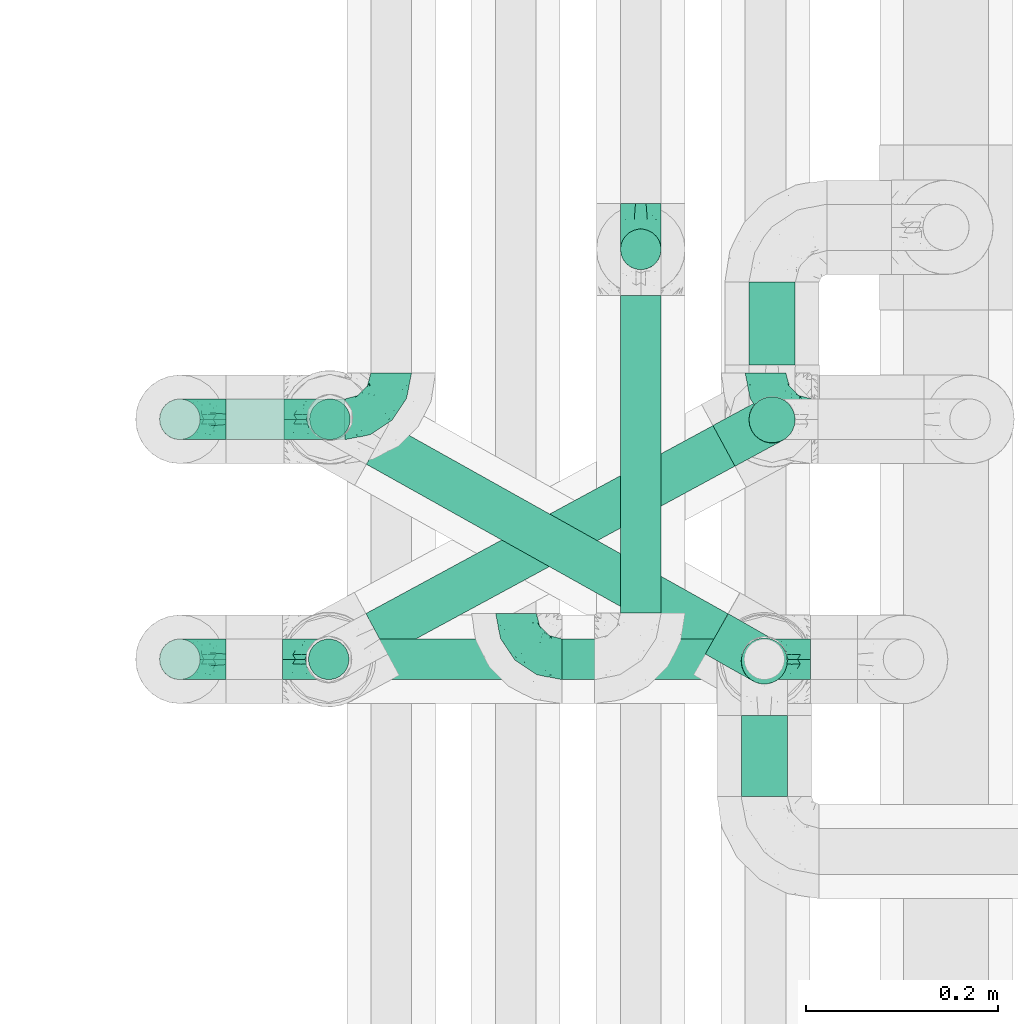
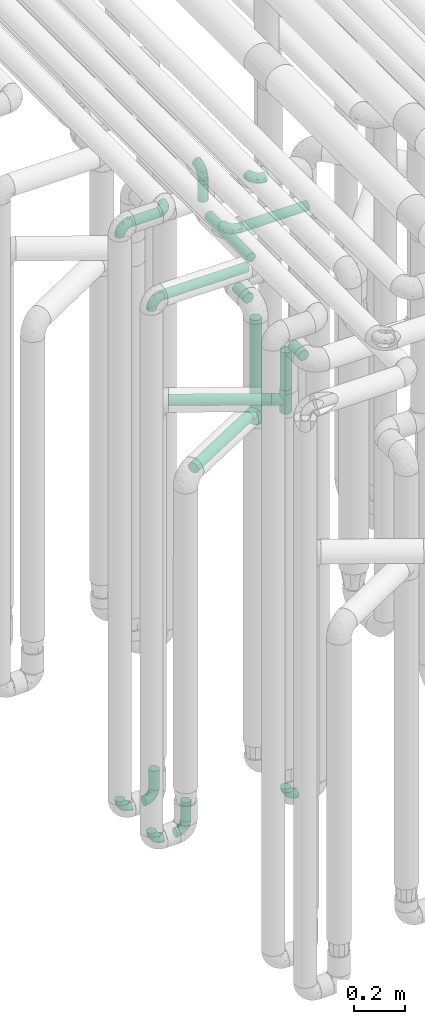
# One storey, part 599 of 824: 13 flow fittings, 13 flow segments.
"""IFC2X3 building model written with IfcOpenShell, lengths in millimetres."""

from ifc_helpers import new_model, entity, si_unit, converted_unit, derived_unit, direction, frame, origin, origin_2d_with_axis, place, context, subcontext, project, spatial, circle, extrude, faceted_brep, source, transform, mapped, material, type_object, type_shapes, element, save


model = new_model("IFC2X3")

# Units and contexts
model_context = context("Model", 3, precision=0.01, world=origin(), true_north=direction((6.12303176911189e-17, 1.0)))
body_context = subcontext(model_context, "Body", "Model", "MODEL_VIEW")
ifc_project = project(units=[si_unit("LENGTHUNIT", "METRE", prefix="MILLI"), si_unit("AREAUNIT", "SQUARE_METRE"), si_unit("VOLUMEUNIT", "CUBIC_METRE"), converted_unit("PLANEANGLEUNIT", "DEGREE", entity("IfcRatioMeasure", 0.0174532925199433), si_unit("PLANEANGLEUNIT", "RADIAN"), dimensions=[0, 0, 0, 0, 0, 0, 0]), si_unit("MASSUNIT", "GRAM", prefix="KILO"), derived_unit("MASSDENSITYUNIT", [(si_unit("MASSUNIT", "GRAM", prefix="KILO"), 1), (si_unit("LENGTHUNIT", "METRE"), -3)]), derived_unit("MOMENTOFINERTIAUNIT", [(si_unit("LENGTHUNIT", "METRE"), 4)]), si_unit("TIMEUNIT", "SECOND"), si_unit("FREQUENCYUNIT", "HERTZ"), si_unit("THERMODYNAMICTEMPERATUREUNIT", "DEGREE_CELSIUS"), derived_unit("THERMALTRANSMITTANCEUNIT", [(si_unit("MASSUNIT", "GRAM", prefix="KILO"), 1), (si_unit("THERMODYNAMICTEMPERATUREUNIT", "KELVIN"), -1), (si_unit("TIMEUNIT", "SECOND"), -3)]), derived_unit("VOLUMETRICFLOWRATEUNIT", [(si_unit("LENGTHUNIT", "METRE"), 3), (si_unit("TIMEUNIT", "SECOND"), -1)]), derived_unit("MASSFLOWRATEUNIT", [(si_unit("MASSUNIT", "GRAM", prefix="KILO"), 1), (si_unit("TIMEUNIT", "SECOND"), -1)]), derived_unit("ROTATIONALFREQUENCYUNIT", [(si_unit("TIMEUNIT", "SECOND"), -1)]), si_unit("ELECTRICCURRENTUNIT", "AMPERE"), si_unit("ELECTRICVOLTAGEUNIT", "VOLT"), si_unit("POWERUNIT", "WATT"), si_unit("FORCEUNIT", "NEWTON", prefix="KILO"), si_unit("ILLUMINANCEUNIT", "LUX"), si_unit("LUMINOUSFLUXUNIT", "LUMEN"), si_unit("LUMINOUSINTENSITYUNIT", "CANDELA"), derived_unit("USERDEFINED", [(si_unit("MASSUNIT", "GRAM", prefix="KILO"), -1), (si_unit("LENGTHUNIT", "METRE"), -2), (si_unit("TIMEUNIT", "SECOND"), 3), (si_unit("LUMINOUSFLUXUNIT", "LUMEN"), 1)]), derived_unit("LINEARVELOCITYUNIT", [(si_unit("LENGTHUNIT", "METRE"), 1), (si_unit("TIMEUNIT", "SECOND"), -1)]), si_unit("PRESSUREUNIT", "PASCAL"), derived_unit("USERDEFINED", [(si_unit("LENGTHUNIT", "METRE"), -2), (si_unit("MASSUNIT", "GRAM", prefix="KILO"), 1), (si_unit("TIMEUNIT", "SECOND"), -2)]), derived_unit("LINEARFORCEUNIT", [(si_unit("MASSUNIT", "GRAM", prefix="KILO"), 1), (si_unit("LENGTHUNIT", "METRE"), 1), (si_unit("TIMEUNIT", "SECOND"), -2), (si_unit("LENGTHUNIT", "METRE"), -1)]), derived_unit("PLANARFORCEUNIT", [(si_unit("MASSUNIT", "GRAM", prefix="KILO"), 1), (si_unit("LENGTHUNIT", "METRE"), 1), (si_unit("TIMEUNIT", "SECOND"), -2), (si_unit("LENGTHUNIT", "METRE"), -2)])], contexts=[model_context])

# Site, building, storey
site_placement = place(None, origin())
site = spatial("IfcSite", under=ifc_project, at=site_placement, CompositionType="ELEMENT")
building_placement = place(site_placement, origin())
building = spatial("IfcBuilding", under=site, at=building_placement, CompositionType="ELEMENT")
storey_placement = place(building_placement, frame((0.0, 0.0, 28200.0)))
storey = spatial("IfcBuildingStorey", under=building, at=storey_placement, CompositionType="ELEMENT", Elevation=28200.0)

# Flow segments
pipe_segment_type = type_object("IfcPipeSegmentType", PredefinedType="NOTDEFINED")
flow_segment_1_placement = place(storey_placement, frame((35253.49, 11783.46, 448.0)))
element("IfcFlowSegment", 1, at=flow_segment_1_placement, inside=storey, type_object=pipe_segment_type, context=body_context, shape_type="SweptSolid", body=[
    extrude(circle(Radius=21.15, at=origin_2d_with_axis()), frame((22.75, 22.75, 0.0), z_axis=(0.0, 0.0, 1.0), x_axis=(-1.0, 0.0, 0.0)), (0.0, 0.0, 1.0), 92.0000000000094),
])
flow_segment_2_placement = place(storey_placement, frame((35252.29, 11533.46, 448.0)))
element("IfcFlowSegment", 2, at=flow_segment_2_placement, inside=storey, type_object=pipe_segment_type, context=body_context, shape_type="SweptSolid", body=[
    extrude(circle(Radius=21.15, at=origin_2d_with_axis()), frame((22.75, 22.75, 0.0), z_axis=(0.0, 0.0, 1.0), x_axis=(-1.0, 0.0, 0.0)), (0.0, 0.0, 1.0), 92.0000000000137),
])
flow_segment_3_placement = place(storey_placement, frame((35168.03, 11783.46, 3177.25)))
element("IfcFlowSegment", 3, at=flow_segment_3_placement, inside=storey, type_object=pipe_segment_type, context=body_context, shape_type="SweptSolid", body=[
    extrude(circle(Radius=21.15, at=origin_2d_with_axis()), frame((0.0, 22.75, 22.75), z_axis=(1.0, 0.0, 0.0), x_axis=(0.0, -1.0, 0.0)), (0.0, 0.0, 1.0), 124.000000000024),
])
flow_segment_4_placement = place(storey_placement, frame((35518.03, 11533.42, 3177.25)))
element("IfcFlowSegment", 4, at=flow_segment_4_placement, inside=storey, type_object=pipe_segment_type, context=body_context, shape_type="SweptSolid", body=[
    extrude(circle(Radius=21.15, at=origin_2d_with_axis()), frame((0.0, 22.75, 22.75), z_axis=(1.0, 0.0, 0.0), x_axis=(0.0, 1.0, 0.0)), (0.0, 0.0, 1.0), 307.750000000047),
])
flow_segment_5_placement = place(storey_placement, frame((35168.03, 11533.44, 2977.25)))
element("IfcFlowSegment", 5, at=flow_segment_5_placement, inside=storey, type_object=pipe_segment_type, context=body_context, shape_type="SweptSolid", body=[
    extrude(circle(Radius=21.15, at=origin_2d_with_axis()), frame((0.0, 22.76, 22.75), z_axis=(1.0, -4.58022354030143e-05, 0.0), x_axis=(4.58022354030143e-05, 1.0, 0.0)), (0.0, 0.0, 1.0), 384.054937940216),
])
flow_segment_6_placement = place(storey_placement, frame((35577.35, 11604.18, 2977.25)))
element("IfcFlowSegment", 6, at=flow_segment_6_placement, inside=storey, type_object=pipe_segment_type, context=body_context, shape_type="SweptSolid", body=[
    extrude(circle(Radius=21.15, at=origin_2d_with_axis()), frame((22.75, 0.0, 22.75), z_axis=(0.0, 1.0, 0.0), x_axis=(-1.0, 0.0, 0.0)), (0.0, 0.0, 1.0), 331.019903361199),
])
flow_segment_7_placement = place(storey_placement, frame((35577.35, 11960.46, 3048.0)))
element("IfcFlowSegment", 7, at=flow_segment_7_placement, inside=storey, type_object=pipe_segment_type, context=body_context, shape_type="SweptSolid", body=[
    extrude(circle(Radius=21.15, at=origin_2d_with_axis()), frame((22.75, 22.75, 0.0)), (0.0, 0.0, 1.0), 104.000000000011),
])
flow_segment_8_placement = place(storey_placement, frame((35711.26, 11780.07, 2157.0)))
element("IfcFlowSegment", 8, at=flow_segment_8_placement, inside=storey, type_object=pipe_segment_type, context=body_context, shape_type="SweptSolid", body=[
    extrude(circle(Radius=24.0, at=origin_2d_with_axis()), frame((25.6, 25.6, 0.0), z_axis=(0.0, 0.0, 1.0), x_axis=(-1.0, 0.0, 0.0)), (0.0, 0.0, 1.0), 385.99999999999),
])
flow_segment_9_placement = place(storey_placement, frame((35703.19, 11528.87, 2362.0)))
element("IfcFlowSegment", 9, at=flow_segment_9_placement, inside=storey, type_object=pipe_segment_type, context=body_context, shape_type="SweptSolid", body=[
    extrude(circle(Radius=24.0, at=origin_2d_with_axis()), frame((25.6, 25.6, 0.0), z_axis=(0.0, 0.0, 1.0), x_axis=(-1.0, 0.0, 0.0)), (0.0, 0.0, 1.0), 180.999999999998),
])
flow_segment_10_placement = place(storey_placement, frame((35312.67, 11560.12, 2279.4)))
element("IfcFlowSegment", 10, at=flow_segment_10_placement, inside=storey, type_object=pipe_segment_type, context=body_context, shape_type="SweptSolid", body=[
    extrude(circle(Radius=24.0, at=origin_2d_with_axis()), frame((13.31, 220.18, 25.6), z_axis=(0.872709848733326, -0.488239203591698, 0.0), x_axis=(-0.488239203591698, -0.872709848733326, 0.0)), (0.0, 0.0, 1.0), 404.791381976554),
])
flow_segment_11_placement = place(storey_placement, frame((35312.16, 11560.04, 2074.4)))
element("IfcFlowSegment", 11, at=flow_segment_11_placement, inside=storey, type_object=pipe_segment_type, context=body_context, shape_type="SweptSolid", body=[
    extrude(circle(Radius=24.0, at=origin_2d_with_axis()), frame((13.02, 22.7, 25.6), z_axis=(0.879349860952551, 0.47617625102763, 0.0), x_axis=(0.47617625102763, -0.879349860952551, 0.0)), (0.0, 0.0, 1.0), 411.156212335712),
])
flow_segment_12_placement = place(storey_placement, frame((35711.26, 11862.67, 2574.4)))
element("IfcFlowSegment", 12, at=flow_segment_12_placement, inside=storey, type_object=pipe_segment_type, context=body_context, shape_type="SweptSolid", body=[
    extrude(circle(Radius=24.0, at=origin_2d_with_axis()), frame((25.6, 0.0, 25.6), z_axis=(0.0, 1.0, 0.0), x_axis=(1.0, 0.0, 0.0)), (0.0, 0.0, 1.0), 86.4113062809591),
])
flow_segment_13_placement = place(storey_placement, frame((35703.19, 11413.08, 2574.4)))
element("IfcFlowSegment", 13, at=flow_segment_13_placement, inside=storey, type_object=pipe_segment_type, context=body_context, shape_type="SweptSolid", body=[
    extrude(circle(Radius=24.0, at=origin_2d_with_axis()), frame((25.6, 0.0, 25.6), z_axis=(0.0, 1.0, 0.0), x_axis=(-1.0, 0.0, 0.0)), (0.0, 0.0, 1.0), 84.3822522691391),
])

# Flow fittings
ifc_material = material()
pipe_fitting_type_1 = type_object("IfcPipeFittingType", PredefinedType="NOTDEFINED", material=ifc_material)
shared_shape_1 = source(origin(), body_context, "Body", "Brep", [
    faceted_brep([(-48.0, 10.6, -18.36), (-48.0, 5.49, -20.48), (-48.0, 0.0, -21.2), (-48.0, -5.49, -20.48), (-48.0, -10.6, -18.36), (-48.0, -14.99, -14.99), (-48.0, -18.36, -10.6), (-48.0, -20.48, -5.49), (-48.0, -21.2, 0.0), (-48.0, -20.48, 5.49), (-48.0, -18.36, 10.6), (-48.0, -14.99, 14.99), (-48.0, -10.6, 18.36), (-48.0, -5.49, 20.48), (-48.0, 0.0, 21.2), (-48.0, 5.49, 20.48), (-48.0, 10.6, 18.36), (-48.0, 14.99, 14.99), (-48.0, 18.36, 10.6), (-48.0, 20.48, 5.49), (-48.0, 21.2, 0.0), (-48.0, 20.48, -5.49), (-48.0, 18.36, -10.6), (-48.0, 14.99, -14.99), (0.0, 48.0, -21.2), (-5.49, 48.0, -20.48), (-10.6, 48.0, -18.36), (-14.99, 48.0, -14.99), (-18.36, 48.0, -10.6), (-20.48, 48.0, -5.49), (-21.2, 48.0, 0.0), (-20.48, 48.0, 5.49), (-18.36, 48.0, 10.6), (-14.99, 48.0, 14.99), (-10.6, 48.0, 18.36), (-5.49, 48.0, 20.48), (0.0, 48.0, 21.2), (5.49, 48.0, 20.48), (10.6, 48.0, 18.36), (14.99, 48.0, 14.99), (18.36, 48.0, 10.6), (20.48, 48.0, 5.49), (21.2, 48.0, 0.0), (20.48, 48.0, -5.49), (18.36, 48.0, -10.6), (14.99, 48.0, -14.99), (10.6, 48.0, -18.36), (5.49, 48.0, -20.48), (-35.25, -16.22, 12.01), (-34.76, -18.57, 0.0), (-20.87, -12.37, 10.9), (-31.49, -11.78, 15.9), (-37.0, -2.58, 20.86), (-33.89, 3.62, 21.15), (-31.81, -18.14, 6.76), (-5.78, 5.78, 17.67), (-19.42, -4.1, 17.86), (-9.6, -3.39, 13.73), (-35.44, -7.73, 19.13), (11.78, 31.49, 15.9), (-5.93, -5.46, 6.95), (-18.45, -13.78, 5.46), (-10.29, -8.43, 0.0), (-24.6, 0.55, 20.62), (-37.28, 17.94, 13.81), (-33.38, 22.85, 9.59), (-41.46, 20.06, 8.75), (-29.51, 20.45, 15.16), (-15.04, 10.79, 21.13), (-7.08, 16.98, 20.93), (-8.39, 23.51, 21.15), (-40.86, 13.03, 17.26), (-8.05, 41.26, 19.83), (-3.21, 35.97, 21.14), (8.53, 19.66, 14.74), (4.1, 19.42, 17.86), (-37.72, 22.66, 4.78), (-37.07, 8.58, 19.98), (-13.0, 5.43, 19.97), (-3.78, 13.93, 19.7), (3.02, 8.69, 13.43), (-2.27, -0.05, 10.65), (6.22, 6.99, 7.09), (-22.25, 34.6, 9.45), (18.14, 31.81, 6.76), (16.22, 35.25, 12.01), (12.37, 20.87, 10.9), (7.73, 35.44, 19.13), (-21.52, -15.93, 0.0), (2.58, 37.0, 20.86), (18.57, 34.76, 0.0), (13.78, 18.45, 5.46), (15.93, 21.52, 0.0), (-20.03, -8.54, 14.9), (-28.6, 28.6, 5.16), (-24.79, 34.6, 0.0), (-34.6, 24.79, 0.0), (-22.81, 37.41, 4.68), (-23.36, 26.33, 14.79), (-13.68, 37.05, 17.49), (-17.72, 38.12, 13.73), (-26.25, 27.3, 11.24), (-9.71, 32.34, 20.14), (-17.26, 25.6, 18.71), (-26.33, 9.99, 20.77), (-24.06, 6.05, 21.2), (-25.02, 15.46, 19.56), (-24.3, 20.72, 17.57), (-31.95, 15.23, 17.8), (-13.53, 24.7, 20.21), (-17.6, 17.6, 20.6), (-0.55, 24.6, 20.62), (-11.41, -7.48, 10.43), (0.93, -0.93, 0.0), (8.43, 10.29, 0.0), (-11.41, -7.48, -10.43), (-20.1, -8.84, -14.66), (-9.6, -3.39, -13.73), (7.73, 35.44, -19.13), (4.1, 19.42, -17.86), (-0.55, 24.6, -20.62), (-38.12, 17.72, -13.73), (-37.05, 13.68, -17.49), (-32.34, 9.71, -20.14), (-41.26, 8.05, -19.83), (-37.41, 22.81, -4.68), (-23.51, 8.39, -21.15), (-35.97, 3.21, -21.14), (-28.6, 28.6, -5.16), (-31.81, -18.14, -6.76), (-18.45, -13.78, -5.46), (-25.6, 17.26, -18.71), (-19.42, -4.1, -17.86), (-17.94, 37.28, -13.81), (-22.85, 33.38, -9.59), (-20.06, 41.46, -8.75), (-31.49, -11.78, -15.9), (-35.25, -16.22, -12.01), (8.53, 19.66, -14.74), (11.78, 31.49, -15.9), (-9.99, 26.33, -20.77), (-6.05, 24.06, -21.2), (-10.79, 15.04, -21.13), (-37.0, -2.58, -20.86), (-16.98, 7.08, -20.93), (-5.43, 13.0, -19.97), (-13.93, 3.78, -19.7), (-20.87, -12.37, -10.9), (-26.33, 23.36, -14.79), (-22.66, 37.72, -4.78), (13.78, 18.45, -5.46), (18.14, 31.81, -6.76), (-15.46, 25.02, -19.56), (-20.72, 24.3, -17.57), (16.22, 35.25, -12.01), (-13.03, 40.86, -17.26), (-8.58, 37.07, -19.98), (2.58, 37.0, -20.86), (-3.62, 33.89, -21.15), (-34.6, 22.25, -9.45), (6.22, 6.99, -7.09), (-20.45, 29.51, -15.16), (-35.44, -7.73, -19.13), (12.37, 20.87, -10.9), (-27.3, 26.25, -11.24), (-15.23, 31.95, -17.8), (-24.7, 13.53, -20.21), (-24.6, 0.55, -20.62), (-5.78, 5.78, -17.67), (-17.6, 17.6, -20.6), (3.02, 8.69, -13.43), (-5.93, -5.46, -6.95), (-2.27, -0.05, -10.65)], [[[0, 1, 2, 3, 4, 5, 6, 7, 8, 9, 10, 11, 12, 13, 14, 15, 16, 17, 18, 19, 20, 21, 22, 23]], [[24, 25, 26, 27, 28, 29, 30, 31, 32, 33, 34, 35, 36, 37, 38, 39, 40, 41, 42, 43, 44, 45, 46, 47]], [[10, 48, 11]], [[9, 8, 49]], [[48, 50, 51]], [[14, 52, 53]], [[10, 54, 48]], [[9, 54, 10]], [[55, 56, 57]], [[51, 12, 11]], [[51, 58, 12]], [[59, 39, 38]], [[60, 61, 62]], [[58, 56, 63]], [[64, 65, 66]], [[67, 65, 64]], [[68, 69, 70]], [[16, 71, 17]], [[13, 52, 14]], [[35, 72, 73]], [[14, 53, 15]], [[17, 64, 18]], [[74, 59, 75]], [[20, 19, 76]], [[66, 19, 18]], [[77, 15, 53]], [[15, 77, 16]], [[69, 78, 79]], [[80, 81, 82]], [[32, 31, 83]], [[84, 85, 86]], [[59, 87, 75]], [[61, 54, 88]], [[36, 89, 37]], [[84, 41, 40]], [[36, 35, 73]], [[90, 41, 84]], [[40, 39, 85]], [[12, 58, 13]], [[85, 84, 40]], [[91, 84, 86]], [[84, 92, 90]], [[87, 38, 37]], [[93, 56, 51]], [[65, 94, 76]], [[94, 95, 96]], [[84, 91, 92]], [[95, 97, 30]], [[98, 99, 100]], [[76, 94, 96]], [[101, 98, 83]], [[100, 99, 33]], [[102, 70, 73]], [[103, 102, 99]], [[94, 97, 95]], [[72, 99, 102]], [[72, 35, 34]], [[34, 33, 99]], [[9, 49, 54]], [[87, 59, 38]], [[104, 105, 68]], [[106, 103, 107]], [[106, 77, 104]], [[71, 64, 17]], [[108, 107, 67]], [[33, 32, 100]], [[109, 103, 110]], [[102, 109, 70]], [[89, 73, 111]], [[50, 48, 54]], [[51, 11, 48]], [[56, 58, 51]], [[88, 54, 49]], [[52, 58, 63]], [[50, 112, 93]], [[56, 55, 78]], [[39, 59, 85]], [[86, 85, 59]], [[89, 87, 37]], [[42, 41, 90]], [[111, 79, 75]], [[111, 75, 87]], [[75, 55, 80]], [[104, 77, 53]], [[71, 77, 108]], [[32, 83, 100]], [[98, 100, 83]], [[99, 98, 103]], [[106, 107, 108]], [[68, 70, 110]], [[111, 73, 70]], [[68, 110, 104]], [[68, 63, 78]], [[57, 93, 112]], [[80, 55, 57]], [[61, 50, 54]], [[80, 82, 86]], [[81, 57, 112]], [[74, 86, 59]], [[60, 113, 82]], [[82, 114, 91]], [[101, 94, 65]], [[97, 94, 83]], [[73, 89, 36]], [[87, 89, 111]], [[58, 52, 13]], [[53, 52, 63]], [[104, 53, 105]], [[106, 104, 110]], [[20, 76, 96]], [[76, 19, 66]], [[103, 106, 110]], [[77, 106, 108]], [[103, 98, 107]], [[67, 107, 98]], [[67, 98, 101]], [[108, 67, 64]], [[53, 63, 105]], [[63, 68, 105]], [[83, 31, 97]], [[30, 97, 31]], [[62, 113, 60]], [[112, 61, 60]], [[61, 88, 62]], [[86, 82, 91]], [[56, 78, 63]], [[114, 82, 113]], [[114, 92, 91]], [[79, 78, 55]], [[75, 79, 55]], [[69, 79, 111]], [[70, 69, 111]], [[78, 69, 68]], [[77, 71, 16]], [[64, 71, 108]], [[64, 66, 18]], [[76, 66, 65]], [[99, 72, 34]], [[73, 72, 102]], [[94, 101, 83]], [[67, 101, 65]], [[75, 80, 74]], [[80, 86, 74]], [[70, 109, 110]], [[102, 103, 109]], [[50, 93, 51]], [[57, 56, 93]], [[61, 112, 50]], [[81, 112, 60]], [[82, 81, 60]], [[80, 57, 81]], [[115, 116, 117]], [[118, 119, 120]], [[121, 122, 23]], [[123, 124, 122]], [[96, 125, 20]], [[123, 126, 127]], [[128, 96, 95]], [[129, 130, 88]], [[123, 122, 131]], [[116, 132, 117]], [[133, 134, 135]], [[0, 124, 1]], [[5, 136, 137]], [[138, 119, 139]], [[129, 88, 49]], [[140, 141, 142]], [[6, 5, 137]], [[46, 118, 47]], [[143, 3, 2]], [[144, 145, 146]], [[6, 129, 7]], [[129, 137, 147]], [[127, 2, 1]], [[148, 122, 121]], [[128, 125, 96]], [[134, 128, 149]], [[95, 149, 128]], [[150, 151, 92]], [[30, 29, 149]], [[152, 131, 153]], [[27, 133, 28]], [[154, 45, 44]], [[136, 5, 4]], [[27, 26, 155]], [[156, 26, 25]], [[24, 157, 158]], [[24, 47, 157]], [[22, 21, 159]], [[160, 150, 114]], [[134, 133, 161]], [[142, 144, 126]], [[46, 139, 118]], [[162, 136, 4]], [[156, 25, 158]], [[1, 124, 127]], [[115, 147, 116]], [[45, 154, 139]], [[139, 46, 45]], [[154, 163, 139]], [[162, 4, 3]], [[42, 90, 43]], [[130, 129, 147]], [[49, 7, 129]], [[43, 151, 44]], [[0, 23, 122]], [[24, 158, 25]], [[136, 162, 132]], [[135, 29, 28]], [[43, 90, 151]], [[164, 148, 159]], [[152, 156, 140]], [[155, 133, 27]], [[165, 153, 161]], [[23, 22, 121]], [[123, 131, 166]], [[123, 166, 126]], [[143, 127, 167]], [[147, 137, 136]], [[8, 7, 49]], [[129, 6, 137]], [[143, 162, 3]], [[167, 146, 132]], [[167, 132, 162]], [[132, 168, 117]], [[44, 151, 154]], [[92, 151, 90]], [[163, 154, 151]], [[119, 118, 139]], [[157, 118, 120]], [[138, 139, 163]], [[119, 168, 145]], [[140, 156, 158]], [[155, 156, 165]], [[22, 159, 121]], [[148, 121, 159]], [[122, 148, 131]], [[152, 153, 165]], [[142, 126, 169]], [[167, 127, 126]], [[142, 169, 140]], [[142, 120, 145]], [[168, 170, 117]], [[160, 171, 172]], [[115, 172, 171]], [[171, 62, 130]], [[119, 170, 168]], [[170, 163, 160]], [[150, 163, 151]], [[113, 171, 160]], [[164, 128, 134]], [[125, 128, 159]], [[127, 143, 2]], [[162, 143, 167]], [[118, 157, 47]], [[158, 157, 120]], [[140, 158, 141]], [[152, 140, 169]], [[30, 149, 95]], [[149, 29, 135]], [[131, 152, 169]], [[156, 152, 165]], [[131, 148, 153]], [[161, 153, 148]], [[161, 148, 164]], [[165, 161, 133]], [[158, 120, 141]], [[120, 142, 141]], [[159, 21, 125]], [[20, 125, 21]], [[115, 130, 147]], [[114, 113, 160]], [[62, 171, 113]], [[62, 88, 130]], [[160, 163, 150]], [[150, 92, 114]], [[119, 145, 120]], [[146, 145, 168]], [[132, 146, 168]], [[144, 146, 167]], [[126, 144, 167]], [[145, 144, 142]], [[156, 155, 26]], [[133, 155, 165]], [[133, 135, 28]], [[149, 135, 134]], [[122, 124, 0]], [[127, 124, 123]], [[128, 164, 159]], [[161, 164, 134]], [[163, 170, 138]], [[170, 119, 138]], [[131, 169, 166]], [[126, 166, 169]], [[147, 136, 116]], [[132, 116, 136]], [[172, 115, 117]], [[130, 115, 171]], [[117, 170, 172]], [[160, 172, 170]]]),
])
type_shapes(pipe_fitting_type_1, [shared_shape_1])
for number, where, z_axis, x_axis in (
    (14, (35276.24, 11806.2, 400.0), (0.0, -1.0, 0.0), (1.0, 0.0, 0.0)),
    (15, (35275.03, 11556.2, 400.0), (0.0, -1.0, 0.0), (1.0, 0.0, 0.0)),
    (16, (35728.78, 11556.17, 400.0), (0.0, 1.0, 0.0), (-1.0, 0.0, 0.0)),
    (17, (35120.03, 11806.2, 400.0), (0.0, 1.0, 0.0), (-1.0, 0.0, 0.0)),
    (18, (35120.03, 11806.2, 3200.0), (0.0, 1.0, 0.0), (0.0, 0.0, 1.0)),
):
    element("IfcFlowFitting", number, at=place(storey_placement, frame(where, z_axis=z_axis, x_axis=x_axis)), inside=storey, type_object=pipe_fitting_type_1, material=ifc_material, context=body_context, shape_type="MappedRepresentation", body=[
        mapped(shared_shape_1, transform((0.0, 0.0, 0.0), scale=1.0)),
    ])
flow_fitting_placement = place(storey_placement, frame((35340.03, 11806.2, 3200.0)))
element("IfcFlowFitting", 19, at=flow_fitting_placement, inside=storey, type_object=pipe_fitting_type_1, material=ifc_material, context=body_context, shape_type="MappedRepresentation", body=[
    mapped(shared_shape_1, transform((0.0, 0.0, 0.0), scale=1.0)),
])
for number, where, z_axis, x_axis in (
    (20, (35470.03, 11556.17, 3200.0), (0.0, 0.0, 1.0), (0.0, -1.0, 0.0)),
    (21, (35730.03, 11806.2, 3200.0), (0.0, 0.0, 1.0), (0.0, -1.0, 0.0)),
    (22, (35120.03, 11556.2, 400.0), (0.0, 1.0, 0.0), (-1.0, 0.0, 0.0)),
    (23, (35600.09, 11983.2, 3200.0), (1.0, 0.0, 0.0), (0.0, -1.0, 0.0)),
    (24, (35120.03, 11556.2, 3000.0), (5.23443422123889e-05, 1.0, 0.0), (0.0, 0.0, 1.0)),
):
    element("IfcFlowFitting", number, at=place(storey_placement, frame(where, z_axis=z_axis, x_axis=x_axis)), inside=storey, type_object=pipe_fitting_type_1, material=ifc_material, context=body_context, shape_type="MappedRepresentation", body=[
        mapped(shared_shape_1, transform((0.0, 0.0, 0.0), scale=1.0)),
    ])
pipe_fitting_type_2 = type_object("IfcPipeFittingType", PredefinedType="NOTDEFINED", material=ifc_material)
shared_shape_2 = source(origin(), body_context, "Body", "Brep", [
    faceted_brep([(-57.0, 12.07, -20.91), (-57.0, 6.25, -23.33), (-57.0, 0.0, -24.15), (-57.0, -6.25, -23.33), (-57.0, -12.08, -20.91), (-57.0, -17.08, -17.08), (-57.0, -20.91, -12.08), (-57.0, -23.33, -6.25), (-57.0, -24.15, 0.0), (-57.0, -23.33, 6.25), (-57.0, -20.91, 12.07), (-57.0, -17.08, 17.08), (-57.0, -12.08, 20.91), (-57.0, -6.25, 23.33), (-57.0, 0.0, 24.15), (-57.0, 6.25, 23.33), (-57.0, 12.07, 20.91), (-57.0, 17.08, 17.08), (-57.0, 20.91, 12.07), (-57.0, 23.33, 6.25), (-57.0, 24.15, 0.0), (-57.0, 23.33, -6.25), (-57.0, 20.91, -12.08), (-57.0, 17.08, -17.08), (57.0, 0.0, -24.15), (57.0, 6.25, -23.33), (57.0, 12.07, -20.91), (57.0, 17.08, -17.08), (57.0, 20.91, -12.08), (57.0, 23.33, -6.25), (57.0, 24.15, 0.0), (57.0, 23.33, 6.25), (57.0, 20.91, 12.07), (57.0, 17.08, 17.08), (57.0, 12.07, 20.91), (57.0, 6.25, 23.33), (57.0, 0.0, 24.15), (57.0, -6.25, 23.33), (57.0, -12.08, 20.91), (57.0, -17.08, 17.08), (57.0, -20.91, 12.07), (57.0, -23.33, 6.25), (57.0, -24.15, 0.0), (57.0, -23.33, -6.25), (57.0, -20.91, -12.08), (57.0, -17.08, -17.08), (57.0, -12.08, -20.91), (57.0, -6.25, -23.33), (23.27, -23.27, 6.45), (24.15, -24.15, 0.0), (-24.15, -24.15, 0.0), (20.9, -20.9, 12.1), (13.54, -13.54, 20.0), (17.52, -17.52, 16.62), (-23.27, -23.27, 6.45), (-20.9, -20.9, 12.1), (-17.52, -17.52, 16.62), (-13.54, -13.54, 20.0), (-9.19, -9.19, 22.33), (9.19, -9.19, 22.33), (4.64, -4.64, 23.7), (0.0, 0.0, 24.15), (-4.64, -4.64, 23.7), (4.64, -4.64, -23.7), (0.0, 0.0, -24.15), (-4.64, -4.64, -23.7), (-9.19, -9.19, -22.33), (9.19, -9.19, -22.33), (13.54, -13.54, -20.0), (17.52, -17.52, -16.62), (20.9, -20.9, -12.1), (23.27, -23.27, -6.45), (-13.54, -13.54, -20.0), (-17.52, -17.52, -16.62), (-23.27, -23.27, -6.45), (-20.9, -20.9, -12.1), (0.0, -57.0, -24.15), (6.25, -57.0, -23.33), (12.08, -57.0, -20.91), (17.08, -57.0, -17.08), (20.91, -57.0, -12.08), (23.33, -57.0, -6.25), (24.15, -57.0, 0.0), (23.33, -57.0, 6.25), (20.91, -57.0, 12.07), (17.08, -57.0, 17.08), (12.08, -57.0, 20.91), (6.25, -57.0, 23.33), (0.0, -57.0, 24.15), (-6.25, -57.0, 23.33), (-12.07, -57.0, 20.91), (-17.08, -57.0, 17.08), (-20.91, -57.0, 12.07), (-23.33, -57.0, 6.25), (-24.15, -57.0, 0.0), (-23.33, -57.0, -6.25), (-20.91, -57.0, -12.08), (-17.08, -57.0, -17.08), (-12.07, -57.0, -20.91), (-6.25, -57.0, -23.33)], [[[0, 1, 2, 3, 4, 5, 6, 7, 8, 9, 10, 11, 12, 13, 14, 15, 16, 17, 18, 19, 20, 21, 22, 23]], [[24, 25, 26, 27, 28, 29, 30, 31, 32, 33, 34, 35, 36, 37, 38, 39, 40, 41, 42, 43, 44, 45, 46, 47]], [[41, 40, 48]], [[42, 41, 49]], [[50, 9, 8]], [[49, 41, 48]], [[40, 51, 48]], [[39, 38, 52]], [[51, 40, 53]], [[52, 53, 39]], [[53, 40, 39]], [[50, 54, 9]], [[9, 54, 10]], [[54, 55, 10]], [[56, 57, 11]], [[11, 10, 56]], [[11, 57, 12]], [[56, 10, 55]], [[12, 57, 58]], [[52, 38, 59]], [[60, 36, 61]], [[62, 61, 14]], [[59, 37, 60]], [[37, 59, 38]], [[60, 37, 36]], [[61, 36, 35, 15, 14]], [[32, 31, 19, 18]], [[17, 16, 34, 33]], [[18, 17, 33, 32]], [[35, 34, 16, 15]], [[20, 19, 31, 30]], [[62, 13, 58]], [[13, 62, 14]], [[58, 13, 12]], [[27, 23, 22, 28]], [[22, 21, 29, 28]], [[0, 23, 27, 26]], [[20, 30, 29, 21]], [[24, 47, 63]], [[24, 64, 2, 1, 25]], [[64, 24, 63]], [[2, 64, 65]], [[26, 25, 1, 0]], [[65, 66, 3]], [[2, 65, 3]], [[66, 4, 3]], [[63, 47, 67]], [[46, 45, 68]], [[69, 68, 45]], [[44, 70, 69]], [[69, 45, 44]], [[46, 68, 67]], [[43, 42, 49]], [[7, 50, 8]], [[43, 71, 44]], [[71, 43, 49]], [[44, 71, 70]], [[72, 4, 66]], [[72, 5, 4]], [[5, 72, 73]], [[5, 73, 6]], [[74, 50, 7]], [[75, 74, 6]], [[74, 7, 6]], [[75, 6, 73]], [[46, 67, 47]], [[76, 77, 78, 79, 80, 81, 82, 83, 84, 85, 86, 87, 88, 89, 90, 91, 92, 93, 94, 95, 96, 97, 98, 99]], [[50, 94, 93]], [[54, 50, 93]], [[91, 90, 57]], [[56, 92, 91]], [[54, 93, 92]], [[58, 90, 89]], [[55, 54, 92]], [[56, 55, 92]], [[58, 57, 90]], [[88, 61, 62]], [[58, 89, 62]], [[56, 91, 57]], [[62, 89, 88]], [[60, 88, 87]], [[86, 59, 87]], [[84, 83, 48]], [[53, 85, 84]], [[52, 86, 85]], [[49, 83, 82]], [[59, 60, 87]], [[52, 59, 86]], [[49, 48, 83]], [[51, 53, 84]], [[48, 51, 84]], [[52, 85, 53]], [[88, 60, 61]], [[82, 81, 49]], [[71, 49, 81]], [[69, 80, 79]], [[79, 78, 68]], [[71, 81, 80]], [[67, 78, 77]], [[70, 71, 80]], [[69, 70, 80]], [[67, 68, 78]], [[76, 64, 63]], [[67, 77, 63]], [[69, 79, 68]], [[63, 77, 76]], [[65, 76, 99]], [[98, 66, 99]], [[96, 95, 74]], [[73, 97, 96]], [[72, 98, 97]], [[50, 95, 94]], [[66, 65, 99]], [[72, 66, 98]], [[50, 74, 95]], [[75, 73, 96]], [[74, 75, 96]], [[72, 97, 73]], [[76, 65, 64]]]),
])
type_shapes(pipe_fitting_type_2, [shared_shape_2])
for number, where, z_axis, x_axis in (
    (25, (35728.78, 11554.46, 2305.0), (0.494757339901246, 0.869031170104872, 0.0), (0.0, 0.0, 1.0)),
    (26, (35736.85, 11805.67, 2100.0), (-0.476176251027639, 0.879349860952547, 0.0), (0.0, 0.0, 1.0)),
):
    element("IfcFlowFitting", number, at=place(storey_placement, frame(where, z_axis=z_axis, x_axis=x_axis)), inside=storey, type_object=pipe_fitting_type_2, material=ifc_material, context=body_context, shape_type="MappedRepresentation", body=[
        mapped(shared_shape_2, transform((0.0, 0.0, 0.0), scale=1.0)),
    ])

save(model, "model.ifc")
